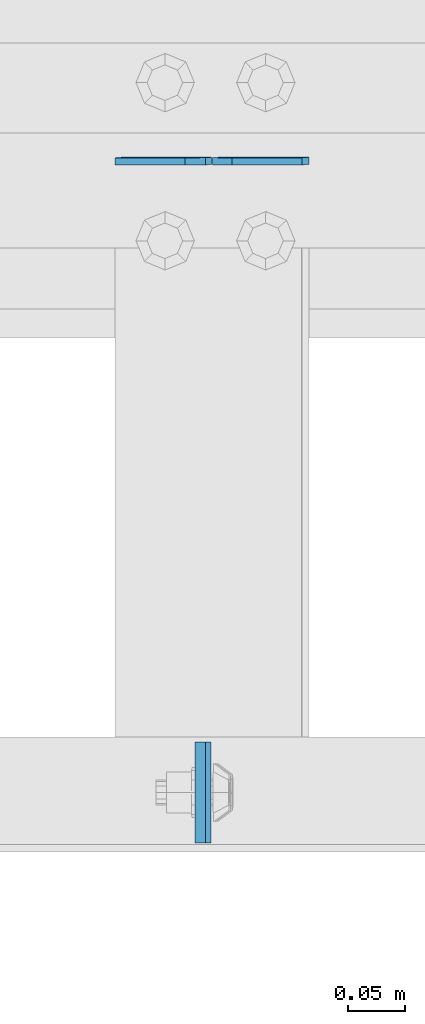
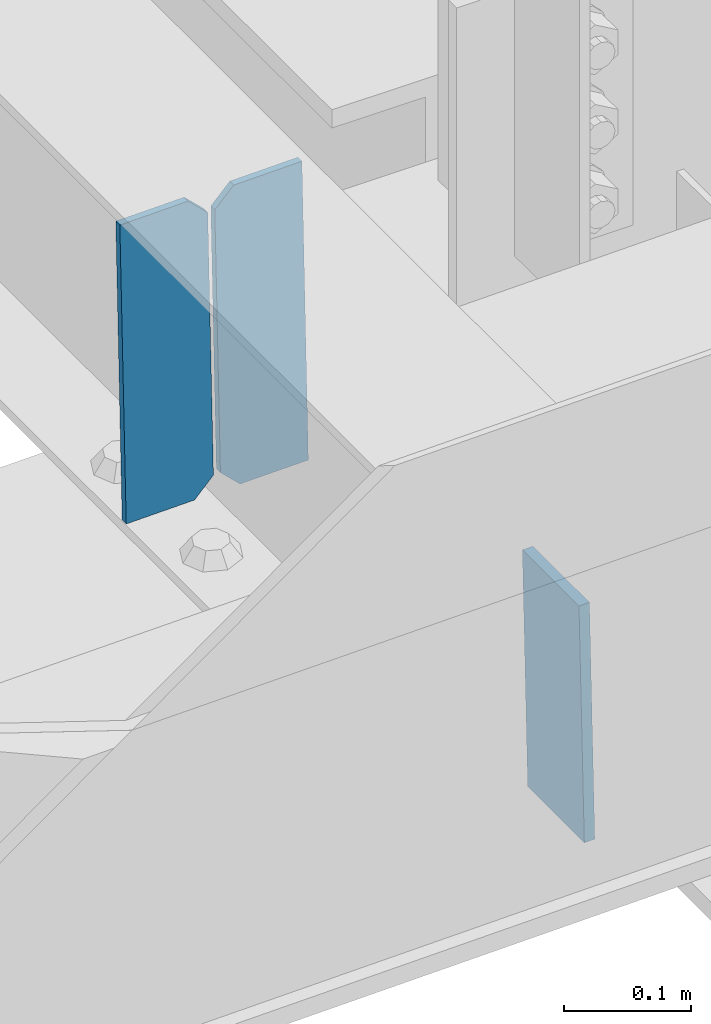
# One storey, part 3191 of 3843: 3 plates, 2 elements without a shape of their own.
"""IFC2X3 building model written with IfcOpenShell, lengths in millimetres."""

from ifc_helpers import new_model, si_unit, frame, origin_with_axes, place, context, subcontext, project, spatial, faceted_brep, material, type_object, element, aggregate, save


model = new_model("IFC2X3")

# Units and contexts
model_context = context("Model", 3, precision=1e-05, world=origin_with_axes())
body_context = subcontext(model_context, "Body", "Model", "MODEL_VIEW")
ifc_project = project(units=[si_unit("LENGTHUNIT", "METRE", prefix="MILLI"), si_unit("AREAUNIT", "SQUARE_METRE"), si_unit("VOLUMEUNIT", "CUBIC_METRE"), si_unit("MASSUNIT", "GRAM", prefix="KILO"), si_unit("TIMEUNIT", "SECOND"), si_unit("PLANEANGLEUNIT", "RADIAN"), si_unit("SOLIDANGLEUNIT", "STERADIAN"), si_unit("THERMODYNAMICTEMPERATUREUNIT", "DEGREE_CELSIUS"), si_unit("LUMINOUSINTENSITYUNIT", "LUMEN")], contexts=[model_context])

# Site, building, storey
site_placement = place(None, origin_with_axes())
site = spatial("IfcSite", under=ifc_project, at=site_placement, CompositionType="ELEMENT")
building_placement = place(site_placement, origin_with_axes())
building = spatial("IfcBuilding", under=site, at=building_placement, Name="Undefined", CompositionType="ELEMENT")
storey_placement = place(building_placement, origin_with_axes())
storey = spatial("IfcBuildingStorey", under=building, at=storey_placement, Name="Undefined", CompositionType="ELEMENT", Elevation=0.0)

# Assembly, plate
assembly_1_placement = place(storey_placement, origin_with_axes())
assembly_1 = element("IfcElementAssembly", 1, at=assembly_1_placement, inside=storey, Name="BEAM", AssemblyPlace="NOTDEFINED", PredefinedType="RIGID_FRAME")
ifc_material = material(Name="STEEL/A572-50")
plate_type_1 = type_object("IfcPlateType", PredefinedType="NOTDEFINED")
plate_1_placement = place(assembly_1_placement, frame((71931.7868821435, 25014.2376945483, 46439.6041079515), z_axis=(4.08280044503044e-05, 0.999999999166164, 8.63789617142174e-07), x_axis=(0.0211520550054438, 0.0, -0.999776270257025)))
plate_1 = element("IfcPlate", 2, at=plate_1_placement, type_object=plate_type_1, material=ifc_material, Name="PLATE", context=body_context, shape_type="Brep", body=[
    faceted_brep([(0.0, -4.76249999999709, 0.0), (0.0, -4.76249999999709, 88.9000015258789), (0.0, 4.76249999999709, 88.9000015258789), (0.0, 4.76249999999709, 0.0), (228.600006102781, -4.7625000004191, 88.9000015257589), (228.600006102781, 4.76249999954598, 88.9000015257443), (228.600006103079, -4.7625000004482, 7.27595761418343e-12), (228.600006103079, 4.76249999954598, -7.27595761418343e-12)], [[[0, 1, 2, 3]], [[1, 4, 5, 2]], [[4, 6, 7, 5]], [[6, 0, 3, 7]], [[5, 7, 3, 2]], [[6, 4, 1, 0]]]),
])
aggregate(assembly_1, [plate_1])

# Assembly, plates
assembly_2_placement = place(storey_placement, origin_with_axes())
assembly_2 = element("IfcElementAssembly", 3, at=assembly_2_placement, inside=storey, Name="BEAM", AssemblyPlace="NOTDEFINED", PredefinedType="RIGID_FRAME")
plate_type_2 = type_object("IfcPlateType", PredefinedType="NOTDEFINED")
plate_2_placement = place(assembly_2_placement, frame((72027.7964782662, 25616.7545539047, 46180.7162546549), z_axis=(-0.0211520984278469, -0.00193019000019922, 0.999774406103028), x_axis=(-0.999776269338345, 4.08370000139469e-05, -0.0211520590071252)))
plate_2 = element("IfcPlate", 4, at=plate_2_placement, type_object=plate_type_2, material=ifc_material, Name="STIFFENER", context=body_context, shape_type="Brep", body=[
    faceted_brep([(0.0, -3.17499999999927, 0.0), (6.83940015733242e-10, -3.17499999996653, 288.924999998613), (6.54836185276508e-10, 3.17500000001746, 288.924999998591), (0.0, 3.17499999999927, 0.0), (61.9125003828667, -3.17499999997744, 288.924999998599), (61.9125003828522, 3.17500000002838, 288.924999998584), (79.3750000013097, -3.17499999997744, 271.462500380039), (79.375000001266, 3.17500000002838, 271.462500380017), (79.375000000713, -3.17499999999927, 17.4624996185448), (79.3750000006694, 3.17500000000291, 17.462499618523), (61.9125003821828, -3.17499999999563, -1.45519152283669e-11), (61.9125003821682, 3.17500000000655, -2.91038304567337e-11)], [[[0, 1, 2, 3]], [[1, 4, 5, 2]], [[4, 6, 7, 5]], [[6, 8, 9, 7]], [[8, 10, 11, 9]], [[10, 0, 3, 11]], [[5, 7, 9, 11, 3, 2]], [[10, 8, 6, 4, 1, 0]]]),
])
plate_3_placement = place(assembly_2_placement, frame((71942.090657576, 25616.7580546312, 46178.9029944332), z_axis=(-0.0211520984278469, -0.00193019000019922, 0.999774406103028), x_axis=(-0.999776269338345, 4.08370000139469e-05, -0.0211520590071252)))
plate_3 = element("IfcPlate", 5, at=plate_3_placement, type_object=plate_type_2, material=ifc_material, Name="STIFFENER", context=body_context, shape_type="Brep", body=[
    faceted_brep([(5.82076609134674e-11, -3.17499999999927, 17.4624996185667), (6.25732354819775e-10, -3.17499999997744, 271.462500380054), (5.82076609134674e-10, 3.17500000002474, 271.462500380039), (0.0, 3.17500000000655, 17.4624996185521), (17.462499619156, -3.17499999997744, 288.924999998606), (17.4624996191269, 3.17500000002474, 288.924999998591), (79.3750000013242, -3.17500000025029, 288.924999998591), (79.3750000013097, 3.1749999997337, 288.92499999857), (79.3750000006548, -3.17500000026484, -2.18278728425503e-11), (79.3750000006403, 3.17499999969732, -2.91038304567337e-11), (17.4624996184866, -3.17500000000291, 7.27595761418343e-12), (17.462499618443, 3.17500000000291, -7.27595761418343e-12)], [[[0, 1, 2, 3]], [[1, 4, 5, 2]], [[4, 6, 7, 5]], [[6, 8, 9, 7]], [[8, 10, 11, 9]], [[10, 0, 3, 11]], [[5, 7, 9, 11, 3, 2]], [[10, 8, 6, 4, 1, 0]]]),
])
aggregate(assembly_2, [plate_2, plate_3])

save(model, "model.ifc")
